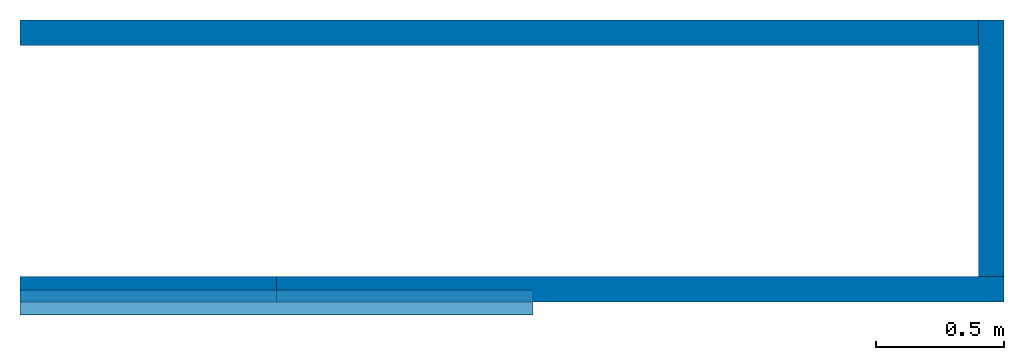
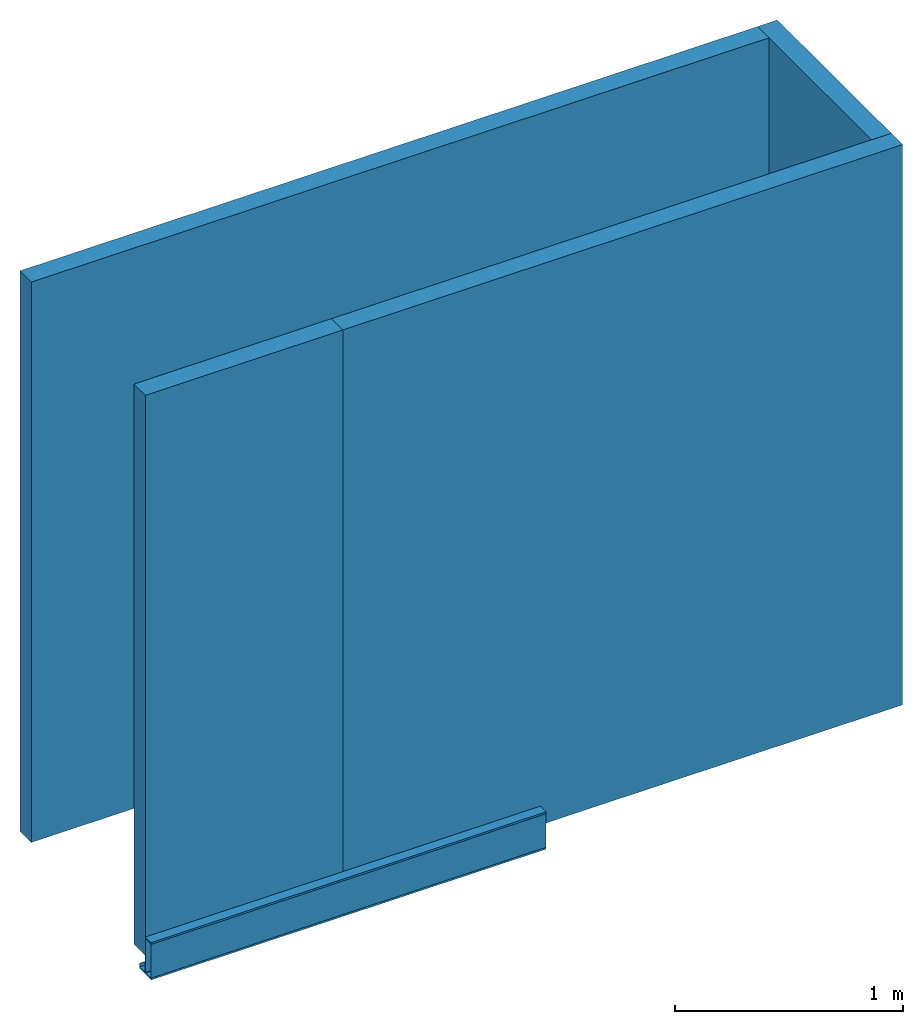
# One storey: 4 walls, 2 beams.
"""IFC4 building model written with IfcOpenShell, lengths in millimetres."""

from ifc_helpers import new_model, entity, si_unit, converted_unit, frame, origin_with_axes, place, context, subcontext, project, spatial, polyline, i_section, c_section, outline, extrude, material, layer, layer_set, layer_usage, material_profile, profile_set, profile_usage, type_object, element, save


model = new_model("IFC4")

# Units and contexts
model_context = context("Model", 3, precision=1e-05)
plan_context = context("Plan", 2, precision=1e-05)
body_context = subcontext(model_context, "Body", "Model", "MODEL_VIEW")
ifc_project = project(units=[si_unit("LENGTHUNIT", "METRE", prefix="MILLI"), converted_unit("PLANEANGLEUNIT", "degree", entity("IfcReal", 0.0174532925199433), si_unit("PLANEANGLEUNIT", "RADIAN"), dimensions=[0, 0, 0, 0, 0, 0, 0]), si_unit("AREAUNIT", "SQUARE_METRE", prefix="MILLI"), si_unit("VOLUMEUNIT", "CUBIC_METRE", prefix="MILLI")], contexts=[model_context, plan_context])

# Site, building, storey
site_placement = place(None, origin_with_axes())
site = spatial("IfcSite", under=ifc_project, at=site_placement)
building_placement = place(site_placement, origin_with_axes())
building = spatial("IfcBuilding", under=site, at=building_placement, Name="Building")
storey_placement = place(building_placement, origin_with_axes())
storey = spatial("IfcBuildingStorey", under=building, at=storey_placement, Name="Storey")

# Beams
ifc_material = material()
ifc_material_profile_1 = material_profile(ifc_material, i_section(OverallWidth=100.0, OverallDepth=200.0, WebThickness=5.0, FlangeThickness=10.0, FilletRadius=5.0))
ifc_profile_set_1 = profile_set([ifc_material_profile_1])
ifc_profile_usage_1 = profile_usage(ifc_profile_set_1)
beam_type_1 = type_object("IfcBeamType", Name="DEMO1", material=ifc_profile_set_1)
beam_1_placement = place(storey_placement, frame((0.0, 0.0, 0.0), z_axis=(1.0, 4.37113882867379e-08, -4.37113882867379e-08), x_axis=(-4.37113882867379e-08, 1.0, 0.0)))
element("IfcBeam", 1, at=beam_1_placement, inside=storey, type_object=beam_type_1, material=ifc_profile_usage_1, Name="Beam", context=body_context, shape_type="SweptSolid", body=[
    extrude(i_section(OverallWidth=100.0, OverallDepth=200.0, WebThickness=5.0, FlangeThickness=10.0, FilletRadius=5.0), None, (0.0, 0.0, 1.0), 2000.0),
])
ifc_material_profile_2 = material_profile(ifc_material, c_section(Depth=200.0, Width=100.0, WallThickness=1.5, Girth=30.0, InternalFilletRadius=5.0))
ifc_profile_set_2 = profile_set([ifc_material_profile_2])
ifc_profile_usage_2 = profile_usage(ifc_profile_set_2)
beam_type_2 = type_object("IfcBeamType", Name="DEMO2", material=ifc_profile_set_2)
beam_2_placement = place(storey_placement, frame((0.0, 0.0, 0.0), z_axis=(1.0, 4.37113882867379e-08, -4.37113882867379e-08), x_axis=(-4.37113882867379e-08, 1.0, 0.0)))
element("IfcBeam", 2, at=beam_2_placement, inside=storey, type_object=beam_type_2, material=ifc_profile_usage_2, Name="Beam", context=body_context, shape_type="SweptSolid", body=[
    extrude(c_section(Depth=200.0, Width=100.0, WallThickness=1.5, Girth=30.0, InternalFilletRadius=5.0), None, (0.0, 0.0, 1.0), 2000.0),
])

# Walls
ifc_layer = layer(ifc_material, 100.0)
ifc_layer_set = layer_set([ifc_layer])
ifc_layer_usage_1 = layer_usage(ifc_layer_set, "AXIS2", "POSITIVE", 0.0)
wall_type = type_object("IfcWallType", Name="DEMO100", material=ifc_layer_set)
wall_1_placement = place(storey_placement, origin_with_axes())
element("IfcWall", 3, at=wall_1_placement, inside=storey, type_object=wall_type, material=ifc_layer_usage_1, Name="Wall", context=body_context, shape_type="SweptSolid", body=[
    extrude(outline(polyline([(-50.0000007450581, -500.0), (50.0000007450581, -500.0), (50.0000007450581, 500.0), (-50.0000007450581, 500.0), (-50.0000007450581, -500.0)])), frame((500.0, 50.0000007450581, 0.0), z_axis=(0.0, 0.0, -1.0), x_axis=(0.0, 1.0, 0.0)), (0.0, 0.0, -1.0), 3000.0),
])
ifc_layer_usage_2 = layer_usage(ifc_layer_set, "AXIS2", "POSITIVE", 0.0)
wall_2_placement = place(storey_placement, origin_with_axes())
element("IfcWall", 4, at=wall_2_placement, inside=storey, type_object=wall_type, material=ifc_layer_usage_2, Name="Wall", context=body_context, shape_type="SweptSolid", body=[
    extrude(outline(polyline([(-50.0000007450581, -1917.78028011322), (50.0000007450581, -1917.78028011322), (50.0000007450581, 1917.78028011322), (-50.0000007450581, 1917.78028011322), (-50.0000007450581, -1917.78028011322)])), frame((1917.78028011322, 50.0000007450581, 0.0), z_axis=(0.0, 0.0, -1.0), x_axis=(0.0, -1.0, 0.0)), (0.0, 0.0, -1.0), 3000.0),
])
ifc_layer_usage_3 = layer_usage(ifc_layer_set, "AXIS2", "POSITIVE", 0.0)
wall_3_placement = place(storey_placement, frame((3835.56056022644, 99.9999046325684, 0.0), z_axis=(0.0, 0.0, 1.0), x_axis=(-4.37113882867379e-08, 1.0, 0.0)))
element("IfcWall", 5, at=wall_3_placement, inside=storey, type_object=wall_type, material=ifc_layer_usage_3, Name="Wall", context=body_context, shape_type="SweptSolid", body=[
    extrude(outline(polyline([(-50.0000007450581, -500.0), (50.0000007450581, -500.0), (50.0000007450581, 500.0), (-50.0000007450581, 500.0), (-50.0000007450581, -500.0)])), frame((500.0, 50.0000007450581, 0.0), z_axis=(0.0, 0.0, -1.0), x_axis=(0.0, 1.0, 0.0)), (0.0, 0.0, -1.0), 3000.0),
])
ifc_layer_usage_4 = layer_usage(ifc_layer_set, "AXIS2", "POSITIVE", 0.0)
wall_4_placement = place(storey_placement, frame((3735.56041717529, 1099.99990463257, 0.0), z_axis=(0.0, 0.0, 1.0), x_axis=(-1.0, -8.74227765734759e-08, 0.0)))
element("IfcWall", 6, at=wall_4_placement, inside=storey, type_object=wall_type, material=ifc_layer_usage_4, Name="Wall", context=body_context, shape_type="SweptSolid", body=[
    extrude(outline(polyline([(-49.99990016222, -1867.78020858765), (49.9998852610588, -1867.78020858765), (50.0000044703484, 1867.78020858765), (-49.9999970197678, 1867.78020858765), (-49.99990016222, -1867.78020858765)])), frame((1867.78020858765, 50.0000044703484, 0.0), z_axis=(0.0, 0.0, -1.0), x_axis=(0.0, -1.0, 0.0)), (0.0, 0.0, -1.0), 3000.0),
])

save(model, "model.ifc")
